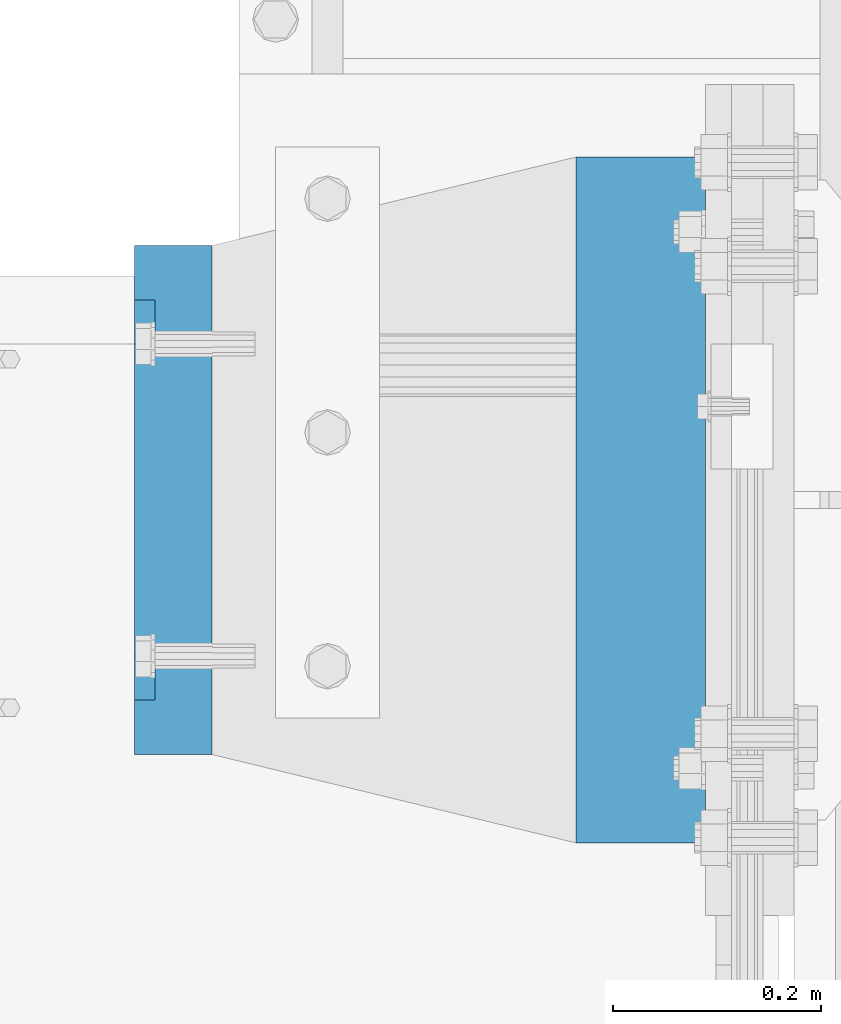
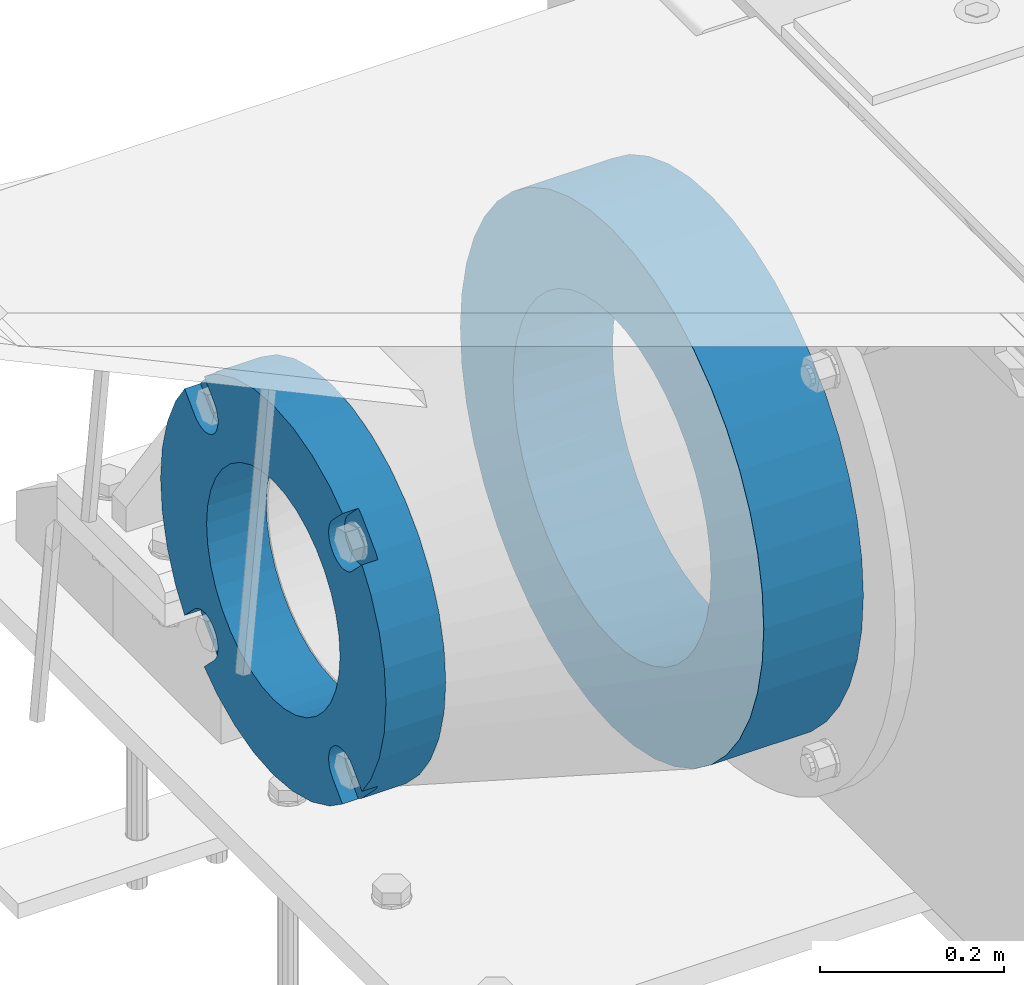
# One storey, part 112 of 193: 2 beams.
"""IFC2X3 building model written with IfcOpenShell, lengths in millimetres."""

from ifc_helpers import new_model, si_unit, frame, origin_with_axes, place, context, subcontext, project, spatial, faceted_brep, material, type_object, element, save


model = new_model("IFC2X3")

# Units and contexts
model_context = context("Model", 3, precision=1e-05, world=origin_with_axes())
body_context = subcontext(model_context, "Body", "Model", "MODEL_VIEW")
ifc_project = project(units=[si_unit("LENGTHUNIT", "METRE", prefix="MILLI"), si_unit("AREAUNIT", "SQUARE_METRE"), si_unit("VOLUMEUNIT", "CUBIC_METRE"), si_unit("MASSUNIT", "GRAM", prefix="KILO"), si_unit("TIMEUNIT", "SECOND"), si_unit("PLANEANGLEUNIT", "RADIAN"), si_unit("SOLIDANGLEUNIT", "STERADIAN"), si_unit("THERMODYNAMICTEMPERATUREUNIT", "DEGREE_CELSIUS"), si_unit("LUMINOUSINTENSITYUNIT", "LUMEN")], contexts=[model_context])

# Site, building, storey
site_placement = place(None, origin_with_axes())
site = spatial("IfcSite", under=ifc_project, at=site_placement, CompositionType="ELEMENT")
building_placement = place(site_placement, origin_with_axes())
building = spatial("IfcBuilding", under=site, at=building_placement, Name="Standard", CompositionType="ELEMENT")
storey_placement = place(building_placement, origin_with_axes())
storey = spatial("IfcBuildingStorey", under=building, at=storey_placement, Name="Undefined", CompositionType="ELEMENT", Elevation=0.0)

# Beams
ifc_material_1 = material(Name="SCN-500-E2")
beam_type_1 = type_object("IfcBeamType", PredefinedType="NOTDEFINED")
beam_1_placement = place(storey_placement, frame((-43000.0, 30000.0000014662, -515.0), z_axis=(0.0, 0.0, 1.0), x_axis=(-1.0, 0.0, 0.0)))
element("IfcBeam", 1, at=beam_1_placement, inside=storey, type_object=beam_type_1, material=ifc_material_1, context=body_context, shape_type="Brep", body=[
    faceted_brep([(75.0, 192.717024793295, -150.290616455866), (75.0, 171.473395903973, -129.046987566545), (55.0, 171.473395903973, -129.046987566545), (55.0, 192.717024793295, -150.290616455869), (75.0, 167.467485558918, -125.685629673588), (55.0, 167.467485558918, -125.685629673588), (75.0, 162.938740320609, -123.070957391173), (55.0, 162.938740320609, -123.070957391173), (75.0, 158.024763821468, -121.282416213608), (55.0, 158.024763821468, -121.282416213608), (75.0, 152.874864750829, -120.374350059533), (55.0, 152.874864750829, -120.374350059533), (75.0, 147.645520185979, -120.37435005953), (55.0, 147.645520185979, -120.37435005953), (75.0, 142.495621115344, -121.282416213611), (55.0, 142.495621115344, -121.282416213611), (75.0, 137.58164461621, -123.070957391175), (55.0, 137.58164461621, -123.070957391175), (75.0, 133.052899377915, -125.685629673596), (55.0, 133.052899377915, -125.685629673596), (75.0, 129.04698903278, -129.046987566545), (55.0, 129.04698903278, -129.046987566545), (75.0, 125.685631139655, -133.052897911658), (55.0, 125.685631139655, -133.052897911658), (75.0, 123.070958857214, -137.581643149977), (55.0, 123.070958857214, -137.581643149977), (75.0, 121.282417679631, -142.49561964913), (55.0, 121.282417679631, -142.49561964913), (75.0, 120.374351525545, -147.64551871979), (55.0, 120.374351525545, -147.64551871979), (75.0, 120.374351525537, -152.874863284665), (55.0, 120.374351525537, -152.874863284665), (75.0, 121.282417679613, -158.024762355333), (55.0, 121.282417679613, -158.024762355333), (75.0, 123.070958857188, -162.938738854498), (55.0, 123.070958857188, -162.938738854498), (75.0, 125.685631139622, -167.467484092835), (55.0, 125.685631139622, -167.467484092835), (75.0, 129.04698903278, -171.473394437738), (55.0, 129.04698903278, -171.473394437738), (55.0, 150.290618180636, -192.717023585595), (75.0, 150.290618180639, -192.717023585596), (55.0, 157.482964373201, -187.68088856415), (55.0, 187.680888564151, -157.482964373202), (75.0, -192.717023585599, 150.290618180639), (75.0, -171.4733929715, 129.046987566545), (55.0, -171.4733929715, 129.046987566545), (55.0, -192.717023585596, 150.290618180642), (75.0, -167.467482626445, 125.685629673588), (55.0, -167.467482626445, 125.685629673588), (75.0, -162.938737388136, 123.070957391173), (55.0, -162.938737388136, 123.070957391173), (75.0, -158.024760888995, 121.282416213608), (55.0, -158.024760888995, 121.282416213608), (75.0, -152.874861818356, 120.374350059533), (55.0, -152.874861818356, 120.374350059533), (75.0, -147.645517253506, 120.37435005953), (55.0, -147.645517253506, 120.37435005953), (75.0, -142.495618182871, 121.282416213611), (55.0, -142.495618182871, 121.282416213611), (75.0, -137.581641683737, 123.070957391176), (55.0, -137.581641683737, 123.070957391176), (75.0, -133.052896445442, 125.685629673596), (55.0, -133.052896445442, 125.685629673596), (75.0, -129.046986100308, 129.046987566545), (55.0, -129.046986100308, 129.046987566545), (75.0, -125.685628207182, 133.052897911658), (55.0, -125.685628207182, 133.052897911658), (75.0, -123.070955924741, 137.581643149977), (55.0, -123.070955924741, 137.581643149977), (75.0, -121.282414747158, 142.49561964913), (55.0, -121.282414747158, 142.49561964913), (75.0, -120.374348593072, 147.64551871979), (55.0, -120.374348593072, 147.64551871979), (75.0, -120.374348593065, 152.874863284665), (55.0, -120.374348593065, 152.874863284665), (75.0, -121.28241474714, 158.024762355333), (55.0, -121.28241474714, 158.024762355333), (75.0, -123.070955924715, 162.938738854498), (55.0, -123.070955924715, 162.938738854498), (75.0, -125.685628207149, 167.467484092835), (55.0, -125.685628207149, 167.467484092835), (75.0, -129.046986100308, 171.473394437738), (55.0, -129.046986100308, 171.473394437738), (55.0, -150.290616455863, 192.717024793293), (75.0, -150.290616455866, 192.717024793293), (75.0, 150.290618180636, 192.717023585598), (75.0, 129.04698903278, 171.473394437739), (55.0, 129.04698903278, 171.473394437739), (55.0, 150.290618180636, 192.717023585597), (75.0, 125.685631139822, 167.467484092685), (55.0, 125.685631139822, 167.467484092685), (75.0, 123.07095885741, 162.938738854374), (55.0, 123.07095885741, 162.938738854374), (75.0, 121.282417679842, 158.024762355234), (55.0, 121.282417679842, 158.024762355234), (75.0, 120.37435152577, 152.874863284594), (55.0, 120.37435152577, 152.874863284594), (75.0, 120.374351525767, 147.645518719745), (55.0, 120.374351525767, 147.645518719745), (75.0, 121.282417679846, 142.495619649111), (55.0, 121.282417679846, 142.495619649111), (75.0, 123.07095885741, 137.581643149976), (55.0, 123.07095885741, 137.581643149976), (75.0, 125.68563113983, 133.05289791168), (55.0, 125.68563113983, 133.05289791168), (75.0, 129.04698903278, 129.046987566546), (55.0, 129.04698903278, 129.046987566546), (75.0, 133.052899377893, 125.685629673422), (55.0, 133.052899377893, 125.685629673422), (75.0, 137.581644616213, 123.070957390979), (55.0, 137.581644616213, 123.070957390979), (75.0, 142.495621115366, 121.282416213396), (55.0, 142.495621115366, 121.282416213396), (75.0, 147.645520186026, 120.374350059311), (55.0, 147.645520186026, 120.374350059311), (75.0, 152.874864750902, 120.374350059303), (55.0, 152.874864750902, 120.374350059303), (75.0, 158.02476382157, 121.28241621338), (55.0, 158.02476382157, 121.28241621338), (75.0, 162.938740320733, 123.070957390956), (55.0, 162.938740320733, 123.070957390956), (75.0, 167.467485559071, 125.685629673386), (55.0, 167.467485559071, 125.685629673386), (75.0, 171.473395903973, 129.046987566546), (55.0, 171.473395903973, 129.046987566546), (55.0, 192.717024793295, 150.29061645587), (75.0, 192.717024793295, 150.290616455869), (0.0, 212.176223927188, -122.5), (0.0, 230.224692092546, -83.7949351147888), (75.0, 230.224692092546, -83.7949351147888), (75.0, 212.176223927188, -122.5), (0.0, 241.277899487992, -42.5438035283978), (75.0, 241.277899487992, -42.5438035283978), (0.0, 245.0, 0.0), (75.0, 245.0, 0.0), (0.0, 241.277899487992, 42.543803528398), (75.0, 241.277899487992, 42.543803528398), (0.0, 230.224692092546, 83.7949351147889), (75.0, 230.224692092546, 83.7949351147889), (0.0, 212.176223927188, 122.5), (75.0, 212.176223927188, 122.5), (0.0, 187.680888564151, 157.482964373202), (55.0, 187.680888564151, 157.482964373202), (0.0, 157.482964373201, 187.68088856415), (55.0, 157.482964373201, 187.68088856415), (0.0, 122.5, 212.176223927187), (75.0, 122.5, 212.176223927187), (0.0, 83.7949351147872, 230.224692092548), (75.0, 83.7949351147872, 230.224692092548), (0.0, 42.5438035283987, 241.277899487991), (75.0, 42.5438035283987, 241.277899487991), (0.0, 0.0, 245.0), (75.0, 0.0, 245.0), (0.0, -42.5438035283987, 241.277899487991), (75.0, -42.5438035283987, 241.277899487991), (0.0, -83.7949351147872, 230.224692092548), (75.0, -83.7949351147872, 230.224692092548), (0.0, -122.5, 212.176223927187), (75.0, -122.5, 212.176223927187), (0.0, -157.482964373201, 187.68088856415), (55.0, -157.482964373201, 187.68088856415), (0.0, -187.680888564151, 157.482964373202), (55.0, -187.680888564151, 157.482964373202), (0.0, -212.176223927188, 122.5), (75.0, -212.176223927188, 122.5), (0.0, -230.224692092546, 83.7949351147888), (75.0, -230.224692092546, 83.7949351147888), (0.0, -241.277899487992, 42.5438035283979), (75.0, -241.277899487992, 42.5438035283979), (0.0, -245.0, 0.0), (75.0, -245.0, 0.0), (0.0, -187.680888564151, -157.482964373202), (0.0, -157.482964373201, -187.68088856415), (55.0, -157.482964373201, -187.68088856415), (55.0, -187.680888564151, -157.482964373202), (0.0, 83.7949351147872, -230.224692092547), (0.0, 122.5, -212.176223927187), (75.0, 122.5, -212.176223927187), (75.0, 83.7949351147872, -230.224692092547), (0.0, 42.5438035283987, -241.277899487991), (75.0, 42.5438035283987, -241.277899487991), (0.0, 0.0, -245.0), (75.0, 0.0, -245.0), (0.0, -42.5438035283987, -241.277899487991), (75.0, -42.5438035283987, -241.277899487991), (0.0, -83.7949351147872, -230.224692092548), (75.0, -83.7949351147872, -230.224692092548), (0.0, -122.5, -212.176223927187), (75.0, -122.5, -212.176223927187), (75.0, -150.290616455863, -192.717024793297), (55.0, -150.290616455863, -192.717024793296), (55.0, -129.046986100308, -171.473394437739), (55.0, -125.68562820735, -167.467484092685), (55.0, -123.070955924937, -162.938738854373), (55.0, -121.282414747369, -158.024762355234), (55.0, -120.374348593297, -152.874863284594), (55.0, -120.374348593294, -147.645518719745), (55.0, -121.282414747373, -142.495619649111), (55.0, -123.070955924937, -137.581643149976), (55.0, -125.685628207357, -133.05289791168), (55.0, -129.046986100308, -129.046987566546), (55.0, -133.052896445421, -125.685629673422), (55.0, -137.581641683741, -123.070957390979), (55.0, -142.495618182893, -121.282416213396), (55.0, -147.645517253553, -120.37435005931), (55.0, -152.874861818429, -120.374350059303), (55.0, -158.024760889097, -121.28241621338), (55.0, -162.93873738826, -123.070957390956), (55.0, -167.467482626598, -125.685629673386), (55.0, -171.4733929715, -129.046987566546), (55.0, -192.717023585596, -150.290618180642), (75.0, -129.046986100308, -171.473394437739), (75.0, -125.68562820735, -167.467484092685), (75.0, -123.070955924937, -162.938738854373), (75.0, -121.282414747369, -158.024762355234), (75.0, -120.374348593297, -152.874863284594), (75.0, -120.374348593294, -147.645518719745), (75.0, -121.282414747373, -142.495619649111), (75.0, -123.070955924937, -137.581643149976), (75.0, -125.685628207357, -133.05289791168), (75.0, -129.046986100308, -129.046987566546), (75.0, -133.052896445421, -125.685629673422), (75.0, -137.581641683741, -123.070957390979), (75.0, -142.495618182893, -121.282416213396), (75.0, -147.645517253553, -120.37435005931), (75.0, -152.874861818429, -120.374350059303), (75.0, -158.024760889097, -121.28241621338), (75.0, -162.93873738826, -123.070957390956), (75.0, -167.467482626598, -125.685629673386), (75.0, -171.4733929715, -129.046987566546), (75.0, -192.717023585596, -150.290618180643), (75.0, -212.176223927188, -122.5), (0.0, -212.176223927188, -122.5), (0.0, -230.224692092546, -83.794935114789), (75.0, -230.224692092546, -83.794935114789), (0.0, -241.277899487992, -42.5438035283979), (75.0, -241.277899487992, -42.5438035283979), (0.0, 187.680888564151, -157.482964373202), (0.0, 157.482964373201, -187.68088856415), (0.0, -142.797124186771, -25.1789857617049), (0.0, -136.255430013956, -49.592920782222), (0.0, -125.573683548744, -72.5), (0.0, -111.076444252252, -93.2042034045483), (0.0, -93.204203404548, -111.076444252252), (0.0, -72.5, -125.573683548744), (0.0, -49.5929207822228, -136.255430013957), (0.0, -25.1789857617041, -142.79712418677), (0.0, 0.0, -145.0), (0.0, 25.1789857617041, -142.79712418677), (0.0, 49.5929207822228, -136.255430013957), (0.0, 72.5, -125.573683548744), (0.0, 93.204203404548, -111.076444252252), (0.0, 111.076444252252, -93.2042034045483), (0.0, 125.573683548744, -72.5), (0.0, 136.255430013956, -49.592920782222), (0.0, 142.797124186771, -25.178985761705), (0.0, 145.0, 0.0), (0.0, 142.797124186771, 25.1789857617048), (0.0, 136.255430013956, 49.5929207822219), (0.0, 125.573683548744, 72.4999999999999), (0.0, 111.076444252252, 93.2042034045482), (0.0, 93.204203404548, 111.076444252252), (0.0, 72.5, 125.573683548744), (0.0, 49.5929207822228, 136.255430013957), (0.0, 25.1789857617041, 142.79712418677), (0.0, 0.0, 145.0), (0.0, -25.1789857617041, 142.79712418677), (0.0, -49.5929207822228, 136.255430013957), (0.0, -72.5, 125.573683548744), (0.0, -93.204203404548, 111.076444252252), (0.0, -111.076444252252, 93.2042034045483), (0.0, -125.573683548744, 72.5000000000001), (0.0, -136.255430013956, 49.5929207822221), (0.0, -142.797124186771, 25.1789857617049), (0.0, -145.0, 0.0), (75.0, -145.0, 0.0), (75.0, -142.797124186771, -25.1789857617049), (75.0, -136.255430013956, -49.592920782222), (75.0, -125.573683548744, -72.5), (75.0, -111.076444252252, -93.2042034045483), (75.0, -93.204203404548, -111.076444252252), (75.0, -72.5, -125.573683548744), (75.0, -49.5929207822228, -136.255430013957), (75.0, -25.1789857617041, -142.79712418677), (75.0, 0.0, -145.0), (75.0, 25.1789857617041, -142.79712418677), (75.0, 49.5929207822228, -136.255430013957), (75.0, 72.5, -125.573683548744), (75.0, 93.204203404548, -111.076444252252), (75.0, 111.076444252252, -93.2042034045483), (75.0, 125.573683548744, -72.5), (75.0, 136.255430013956, -49.592920782222), (75.0, 142.797124186771, -25.178985761705), (75.0, 145.0, 0.0), (75.0, 142.797124186771, 25.1789857617048), (75.0, 136.255430013956, 49.5929207822219), (75.0, 125.573683548744, 72.4999999999999), (75.0, 111.076444252252, 93.2042034045482), (75.0, 93.204203404548, 111.076444252252), (75.0, 72.5, 125.573683548744), (75.0, 49.5929207822228, 136.255430013957), (75.0, 25.1789857617041, 142.79712418677), (75.0, 0.0, 145.0), (75.0, -25.1789857617041, 142.79712418677), (75.0, -49.5929207822228, 136.255430013957), (75.0, -72.5, 125.573683548744), (75.0, -93.204203404548, 111.076444252252), (75.0, -111.076444252252, 93.2042034045483), (75.0, -125.573683548744, 72.5000000000001), (75.0, -136.255430013956, 49.5929207822221), (75.0, -142.797124186771, 25.1789857617049)], [[[0, 1, 2, 3]], [[4, 5, 2, 1]], [[6, 7, 5, 4]], [[8, 9, 7, 6]], [[10, 11, 9, 8]], [[12, 13, 11, 10]], [[14, 15, 13, 12]], [[16, 17, 15, 14]], [[18, 19, 17, 16]], [[20, 21, 19, 18]], [[22, 23, 21, 20]], [[24, 25, 23, 22]], [[26, 27, 25, 24]], [[28, 29, 27, 26]], [[30, 31, 29, 28]], [[32, 33, 31, 30]], [[34, 35, 33, 32]], [[36, 37, 35, 34]], [[38, 39, 37, 36]], [[40, 39, 38, 41]], [[42, 43, 3, 2, 5, 7, 9, 11, 13, 15, 17, 19, 21, 23, 25, 27, 29, 31, 33, 35, 37, 39, 40]], [[44, 45, 46, 47]], [[48, 49, 46, 45]], [[50, 51, 49, 48]], [[52, 53, 51, 50]], [[54, 55, 53, 52]], [[56, 57, 55, 54]], [[58, 59, 57, 56]], [[60, 61, 59, 58]], [[62, 63, 61, 60]], [[64, 65, 63, 62]], [[66, 67, 65, 64]], [[68, 69, 67, 66]], [[70, 71, 69, 68]], [[72, 73, 71, 70]], [[74, 75, 73, 72]], [[76, 77, 75, 74]], [[78, 79, 77, 76]], [[80, 81, 79, 78]], [[82, 83, 81, 80]], [[84, 83, 82, 85]], [[86, 87, 88, 89]], [[90, 91, 88, 87]], [[92, 93, 91, 90]], [[94, 95, 93, 92]], [[96, 97, 95, 94]], [[98, 99, 97, 96]], [[100, 101, 99, 98]], [[102, 103, 101, 100]], [[104, 105, 103, 102]], [[106, 107, 105, 104]], [[108, 109, 107, 106]], [[110, 111, 109, 108]], [[112, 113, 111, 110]], [[114, 115, 113, 112]], [[116, 117, 115, 114]], [[118, 119, 117, 116]], [[120, 121, 119, 118]], [[122, 123, 121, 120]], [[124, 125, 123, 122]], [[126, 125, 124, 127]], [[128, 129, 130, 131]], [[129, 132, 133, 130]], [[132, 134, 135, 133]], [[134, 136, 137, 135]], [[136, 138, 139, 137]], [[138, 140, 141, 139]], [[127, 141, 140, 142, 143, 126]], [[142, 144, 145, 143]], [[89, 88, 91, 93, 95, 97, 99, 101, 103, 105, 107, 109, 111, 113, 115, 117, 119, 121, 123, 125, 126, 143, 145]], [[144, 146, 147, 86, 89, 145]], [[146, 148, 149, 147]], [[148, 150, 151, 149]], [[150, 152, 153, 151]], [[152, 154, 155, 153]], [[154, 156, 157, 155]], [[156, 158, 159, 157]], [[85, 159, 158, 160, 161, 84]], [[160, 162, 163, 161]], [[47, 46, 49, 51, 53, 55, 57, 59, 61, 63, 65, 67, 69, 71, 73, 75, 77, 79, 81, 83, 84, 161, 163]], [[162, 164, 165, 44, 47, 163]], [[164, 166, 167, 165]], [[166, 168, 169, 167]], [[168, 170, 171, 169]], [[172, 173, 174, 175]], [[176, 177, 178, 179]], [[180, 176, 179, 181]], [[182, 180, 181, 183]], [[184, 182, 183, 185]], [[186, 184, 185, 187]], [[188, 186, 187, 189]], [[173, 188, 189, 190, 191, 174]], [[175, 174, 191, 192, 193, 194, 195, 196, 197, 198, 199, 200, 201, 202, 203, 204, 205, 206, 207, 208, 209, 210, 211]], [[190, 212, 192, 191]], [[213, 193, 192, 212]], [[214, 194, 193, 213]], [[215, 195, 194, 214]], [[216, 196, 195, 215]], [[217, 197, 196, 216]], [[218, 198, 197, 217]], [[219, 199, 198, 218]], [[220, 200, 199, 219]], [[221, 201, 200, 220]], [[222, 202, 201, 221]], [[223, 203, 202, 222]], [[224, 204, 203, 223]], [[225, 205, 204, 224]], [[226, 206, 205, 225]], [[227, 207, 206, 226]], [[228, 208, 207, 227]], [[229, 209, 208, 228]], [[230, 210, 209, 229]], [[211, 210, 230, 231]], [[232, 233, 172, 175, 211, 231]], [[234, 233, 232, 235]], [[236, 234, 235, 237]], [[170, 236, 237, 171]], [[168, 166, 164, 162, 160, 158, 156, 154, 152, 150, 148, 146, 144, 142, 140, 138, 136, 134, 132, 129, 128, 238, 239, 177, 176, 180, 182, 184, 186, 188, 173, 172, 233, 234, 236, 170], [240, 241, 242, 243, 244, 245, 246, 247, 248, 249, 250, 251, 252, 253, 254, 255, 256, 257, 258, 259, 260, 261, 262, 263, 264, 265, 266, 267, 268, 269, 270, 271, 272, 273, 274, 275]], [[240, 275, 276, 277]], [[241, 240, 277, 278]], [[242, 241, 278, 279]], [[243, 242, 279, 280]], [[244, 243, 280, 281]], [[245, 244, 281, 282]], [[246, 245, 282, 283]], [[247, 246, 283, 284]], [[248, 247, 284, 285]], [[249, 248, 285, 286]], [[250, 249, 286, 287]], [[251, 250, 287, 288]], [[252, 251, 288, 289]], [[253, 252, 289, 290]], [[254, 253, 290, 291]], [[255, 254, 291, 292]], [[256, 255, 292, 293]], [[257, 256, 293, 294]], [[258, 257, 294, 295]], [[259, 258, 295, 296]], [[260, 259, 296, 297]], [[261, 260, 297, 298]], [[262, 261, 298, 299]], [[263, 262, 299, 300]], [[264, 263, 300, 301]], [[265, 264, 301, 302]], [[266, 265, 302, 303]], [[267, 266, 303, 304]], [[268, 267, 304, 305]], [[269, 268, 305, 306]], [[270, 269, 306, 307]], [[271, 270, 307, 308]], [[272, 271, 308, 309]], [[273, 272, 309, 310]], [[274, 273, 310, 311]], [[275, 274, 311, 276]], [[24, 22, 20, 18, 16, 14, 12, 10, 8, 6, 4, 1, 0, 131, 130, 133, 135, 137, 139, 141, 127, 124, 122, 120, 118, 116, 114, 112, 110, 108, 106, 104, 102, 100, 98, 96, 94, 92, 90, 87, 86, 147, 149, 151, 153, 155, 157, 159, 85, 82, 80, 78, 76, 74, 72, 70, 68, 66, 64, 62, 60, 58, 56, 54, 52, 50, 48, 45, 44, 165, 167, 169, 171, 237, 235, 232, 231, 230, 229, 228, 227, 226, 225, 224, 223, 222, 221, 220, 219, 218, 217, 216, 215, 214, 213, 212, 190, 189, 187, 185, 183, 181, 179, 178, 41, 38, 36, 34, 32, 30, 28, 26], [310, 309, 308, 307, 306, 305, 304, 303, 302, 301, 300, 299, 298, 297, 296, 295, 294, 293, 292, 291, 290, 289, 288, 287, 286, 285, 284, 283, 282, 281, 280, 279, 278, 277, 276, 311]], [[238, 128, 131, 0, 3, 43]], [[239, 238, 43, 42]], [[178, 177, 239, 42, 40, 41]]]),
])
ifc_material_2 = material(Name="STEEL/S355N")
beam_type_2 = type_object("IfcBeamType", PredefinedType="NOTDEFINED")
beam_2_placement = place(storey_placement, frame((-42525.0, 30000.0, -515.0), z_axis=(0.0, 0.0, 1.0), x_axis=(-1.0, 0.0, 0.0)))
element("IfcBeam", 2, at=beam_2_placement, inside=storey, type_object=beam_type_2, material=ifc_material_2, context=body_context, shape_type="Brep", body=[
    faceted_brep([(0.0, -215.0, 0.0), (0.0, -212.811610004399, 30.5976902287563), (125.0, -212.811610004399, 30.5976902287563), (125.0, -215.0, 0.0), (0.0, -206.290989327117, 60.5724997209074), (125.0, -206.290989327117, 60.5724997209074), (0.0, -195.570879001221, 89.3142277954056), (125.0, -195.570879001221, 89.3142277954056), (0.0, -180.869509558703, 116.237775752953), (125.0, -180.869509558703, 116.237775752953), (0.0, -162.486158486165, 140.795057798236), (125.0, -162.486158486165, 140.795057798236), (0.0, -140.795057798237, 162.486158486165), (125.0, -140.795057798237, 162.486158486165), (0.0, -116.237775752954, 180.869509558704), (125.0, -116.237775752954, 180.869509558704), (0.0, -89.3142277954066, 195.570879001222), (125.0, -89.3142277954066, 195.570879001222), (0.0, -60.5724997209072, 206.290989327117), (125.0, -60.5724997209072, 206.290989327117), (0.0, -30.5976902287548, 212.811610004401), (125.0, -30.5976902287548, 212.811610004401), (0.0, 0.0, 215.0), (125.0, 0.0, 215.0), (0.0, 30.5976902287548, 212.811610004401), (125.0, 30.5976902287548, 212.811610004401), (0.0, 60.5724997209072, 206.290989327117), (125.0, 60.5724997209072, 206.290989327117), (0.0, 89.3142277954066, 195.570879001221), (125.0, 89.3142277954066, 195.570879001221), (0.0, 116.237775752954, 180.869509558704), (125.0, 116.237775752954, 180.869509558704), (0.0, 140.795057798237, 162.486158486165), (125.0, 140.795057798237, 162.486158486165), (0.0, 162.486158486165, 140.795057798236), (125.0, 162.486158486165, 140.795057798236), (0.0, 180.869509558703, 116.237775752953), (125.0, 180.869509558703, 116.237775752953), (0.0, 195.570879001221, 89.3142277954056), (125.0, 195.570879001221, 89.3142277954056), (0.0, 206.290989327117, 60.5724997209073), (125.0, 206.290989327117, 60.5724997209073), (0.0, 212.811610004399, 30.5976902287563), (125.0, 212.811610004399, 30.5976902287563), (0.0, 215.0, 0.0), (125.0, 215.0, 0.0), (0.0, 212.811610004399, -30.5976902287563), (125.0, 212.811610004399, -30.5976902287563), (0.0, 206.290989327117, -60.5724997209073), (125.0, 206.290989327117, -60.5724997209073), (0.0, 195.570879001221, -89.3142277954056), (125.0, 195.570879001221, -89.3142277954056), (0.0, 180.869509558703, -116.237775752954), (125.0, 180.869509558703, -116.237775752954), (0.0, 162.486158486165, -140.795057798236), (125.0, 162.486158486165, -140.795057798236), (0.0, 140.795057798237, -162.486158486166), (125.0, 140.795057798237, -162.486158486166), (0.0, 116.237775752954, -180.869509558704), (125.0, 116.237775752954, -180.869509558704), (0.0, 89.3142277954066, -195.570879001221), (125.0, 89.3142277954066, -195.570879001221), (0.0, 60.5724997209072, -206.290989327117), (125.0, 60.5724997209072, -206.290989327117), (0.0, 30.5976902287548, -212.811610004401), (125.0, 30.5976902287548, -212.811610004401), (0.0, 0.0, -215.0), (125.0, 0.0, -215.0), (0.0, -30.5976902287548, -212.811610004401), (125.0, -30.5976902287548, -212.811610004401), (0.0, -60.5724997209072, -206.290989327117), (125.0, -60.5724997209072, -206.290989327117), (0.0, -89.3142277954066, -195.570879001221), (125.0, -89.3142277954066, -195.570879001221), (0.0, -116.237775752954, -180.869509558704), (125.0, -116.237775752954, -180.869509558704), (0.0, -140.795057798237, -162.486158486166), (125.0, -140.795057798237, -162.486158486166), (0.0, -162.486158486165, -140.795057798236), (125.0, -162.486158486165, -140.795057798236), (0.0, -180.869509558703, -116.237775752953), (125.0, -180.869509558703, -116.237775752953), (0.0, -195.570879001221, -89.3142277954056), (125.0, -195.570879001221, -89.3142277954056), (0.0, -206.290989327117, -60.5724997209073), (125.0, -206.290989327117, -60.5724997209073), (0.0, -212.811610004399, -30.5976902287563), (125.0, -212.811610004399, -30.5976902287563), (0.0, -330.0, 0.0), (0.0, -326.641075820709, -46.9638966301842), (125.0, -326.641075820709, -46.9638966301842), (125.0, -330.0, 0.0), (0.0, -316.632681292784, -92.9717437576718), (125.0, -316.632681292784, -92.9717437576718), (0.0, -300.178558466992, -137.086954290623), (125.0, -300.178558466992, -137.086954290623), (0.0, -277.613665834291, -178.411469760347), (125.0, -277.613665834291, -178.411469760347), (0.0, -249.397359536906, -216.104042201944), (125.0, -249.397359536906, -216.104042201944), (0.0, -216.104042201943, -249.397359536905), (125.0, -216.104042201943, -249.397359536905), (0.0, -178.411469760347, -277.61366583429), (125.0, -178.411469760347, -277.61366583429), (0.0, -137.086954290622, -300.178558466991), (125.0, -137.086954290622, -300.178558466991), (0.0, -92.9717437576728, -316.632681292784), (125.0, -92.9717437576728, -316.632681292784), (0.0, -46.9638966301827, -326.641075820708), (125.0, -46.9638966301827, -326.641075820708), (0.0, 0.0, -330.0), (125.0, 0.0, -330.0), (0.0, 46.9638966301827, -326.641075820708), (125.0, 46.9638966301827, -326.641075820708), (0.0, 92.9717437576728, -316.632681292784), (125.0, 92.9717437576728, -316.632681292784), (0.0, 137.086954290622, -300.178558466991), (125.0, 137.086954290622, -300.178558466991), (0.0, 178.411469760347, -277.61366583429), (125.0, 178.411469760347, -277.61366583429), (0.0, 216.104042201943, -249.397359536905), (125.0, 216.104042201943, -249.397359536905), (0.0, 249.397359536906, -216.104042201944), (125.0, 249.397359536906, -216.104042201944), (0.0, 277.613665834291, -178.411469760347), (125.0, 277.613665834291, -178.411469760347), (0.0, 300.178558466992, -137.086954290623), (125.0, 300.178558466992, -137.086954290623), (0.0, 316.632681292784, -92.9717437576717), (125.0, 316.632681292784, -92.9717437576717), (0.0, 326.641075820709, -46.9638966301841), (125.0, 326.641075820709, -46.9638966301841), (0.0, 330.0, 0.0), (125.0, 330.0, 0.0), (0.0, 326.641075820709, 46.9638966301841), (125.0, 326.641075820709, 46.9638966301841), (0.0, 316.632681292784, 92.9717437576718), (125.0, 316.632681292784, 92.9717437576718), (0.0, 300.178558466992, 137.086954290622), (125.0, 300.178558466992, 137.086954290622), (0.0, 277.613665834291, 178.411469760347), (125.0, 277.613665834291, 178.411469760347), (0.0, 249.397359536906, 216.104042201944), (125.0, 249.397359536906, 216.104042201944), (0.0, 216.104042201943, 249.397359536905), (125.0, 216.104042201943, 249.397359536905), (0.0, 178.411469760347, 277.61366583429), (125.0, 178.411469760347, 277.61366583429), (0.0, 137.086954290622, 300.178558466991), (125.0, 137.086954290622, 300.178558466991), (0.0, 92.9717437576728, 316.632681292784), (125.0, 92.9717437576728, 316.632681292784), (0.0, 46.9638966301827, 326.641075820708), (125.0, 46.9638966301827, 326.641075820708), (0.0, 0.0, 330.0), (125.0, 0.0, 330.0), (0.0, -46.9638966301827, 326.641075820708), (125.0, -46.9638966301827, 326.641075820708), (0.0, -92.9717437576728, 316.632681292784), (125.0, -92.9717437576728, 316.632681292784), (0.0, -137.086954290622, 300.178558466991), (125.0, -137.086954290622, 300.178558466991), (0.0, -178.411469760347, 277.61366583429), (125.0, -178.411469760347, 277.61366583429), (0.0, -216.104042201943, 249.397359536905), (125.0, -216.104042201943, 249.397359536905), (0.0, -249.397359536906, 216.104042201944), (125.0, -249.397359536906, 216.104042201944), (0.0, -277.613665834291, 178.411469760347), (125.0, -277.613665834291, 178.411469760347), (0.0, -300.178558466992, 137.086954290623), (125.0, -300.178558466992, 137.086954290623), (0.0, -316.632681292784, 92.9717437576718), (125.0, -316.632681292784, 92.9717437576718), (0.0, -326.641075820709, 46.9638966301841), (125.0, -326.641075820709, 46.9638966301841)], [[[0, 1, 2, 3]], [[1, 4, 5, 2]], [[4, 6, 7, 5]], [[6, 8, 9, 7]], [[8, 10, 11, 9]], [[10, 12, 13, 11]], [[12, 14, 15, 13]], [[14, 16, 17, 15]], [[16, 18, 19, 17]], [[18, 20, 21, 19]], [[20, 22, 23, 21]], [[22, 24, 25, 23]], [[24, 26, 27, 25]], [[26, 28, 29, 27]], [[28, 30, 31, 29]], [[30, 32, 33, 31]], [[32, 34, 35, 33]], [[34, 36, 37, 35]], [[36, 38, 39, 37]], [[38, 40, 41, 39]], [[40, 42, 43, 41]], [[42, 44, 45, 43]], [[44, 46, 47, 45]], [[46, 48, 49, 47]], [[48, 50, 51, 49]], [[50, 52, 53, 51]], [[52, 54, 55, 53]], [[54, 56, 57, 55]], [[56, 58, 59, 57]], [[58, 60, 61, 59]], [[60, 62, 63, 61]], [[62, 64, 65, 63]], [[64, 66, 67, 65]], [[66, 68, 69, 67]], [[68, 70, 71, 69]], [[70, 72, 73, 71]], [[72, 74, 75, 73]], [[74, 76, 77, 75]], [[76, 78, 79, 77]], [[78, 80, 81, 79]], [[80, 82, 83, 81]], [[82, 84, 85, 83]], [[84, 86, 87, 85]], [[86, 0, 3, 87]], [[88, 89, 90, 91]], [[89, 92, 93, 90]], [[92, 94, 95, 93]], [[94, 96, 97, 95]], [[96, 98, 99, 97]], [[98, 100, 101, 99]], [[100, 102, 103, 101]], [[102, 104, 105, 103]], [[104, 106, 107, 105]], [[106, 108, 109, 107]], [[108, 110, 111, 109]], [[110, 112, 113, 111]], [[112, 114, 115, 113]], [[114, 116, 117, 115]], [[116, 118, 119, 117]], [[118, 120, 121, 119]], [[120, 122, 123, 121]], [[122, 124, 125, 123]], [[124, 126, 127, 125]], [[126, 128, 129, 127]], [[128, 130, 131, 129]], [[130, 132, 133, 131]], [[132, 134, 135, 133]], [[134, 136, 137, 135]], [[136, 138, 139, 137]], [[138, 140, 141, 139]], [[140, 142, 143, 141]], [[142, 144, 145, 143]], [[144, 146, 147, 145]], [[146, 148, 149, 147]], [[148, 150, 151, 149]], [[150, 152, 153, 151]], [[152, 154, 155, 153]], [[154, 156, 157, 155]], [[156, 158, 159, 157]], [[158, 160, 161, 159]], [[160, 162, 163, 161]], [[162, 164, 165, 163]], [[164, 166, 167, 165]], [[166, 168, 169, 167]], [[168, 170, 171, 169]], [[170, 172, 173, 171]], [[172, 174, 175, 173]], [[174, 88, 91, 175]], [[93, 95, 97, 99, 101, 103, 105, 107, 109, 111, 113, 115, 117, 119, 121, 123, 125, 127, 129, 131, 133, 135, 137, 139, 141, 143, 145, 147, 149, 151, 153, 155, 157, 159, 161, 163, 165, 167, 169, 171, 173, 175, 91, 90], [5, 7, 9, 11, 13, 15, 17, 19, 21, 23, 25, 27, 29, 31, 33, 35, 37, 39, 41, 43, 45, 47, 49, 51, 53, 55, 57, 59, 61, 63, 65, 67, 69, 71, 73, 75, 77, 79, 81, 83, 85, 87, 3, 2]], [[174, 172, 170, 168, 166, 164, 162, 160, 158, 156, 154, 152, 150, 148, 146, 144, 142, 140, 138, 136, 134, 132, 130, 128, 126, 124, 122, 120, 118, 116, 114, 112, 110, 108, 106, 104, 102, 100, 98, 96, 94, 92, 89, 88], [86, 84, 82, 80, 78, 76, 74, 72, 70, 68, 66, 64, 62, 60, 58, 56, 54, 52, 50, 48, 46, 44, 42, 40, 38, 36, 34, 32, 30, 28, 26, 24, 22, 20, 18, 16, 14, 12, 10, 8, 6, 4, 1, 0]]]),
])

save(model, "model.ifc")
